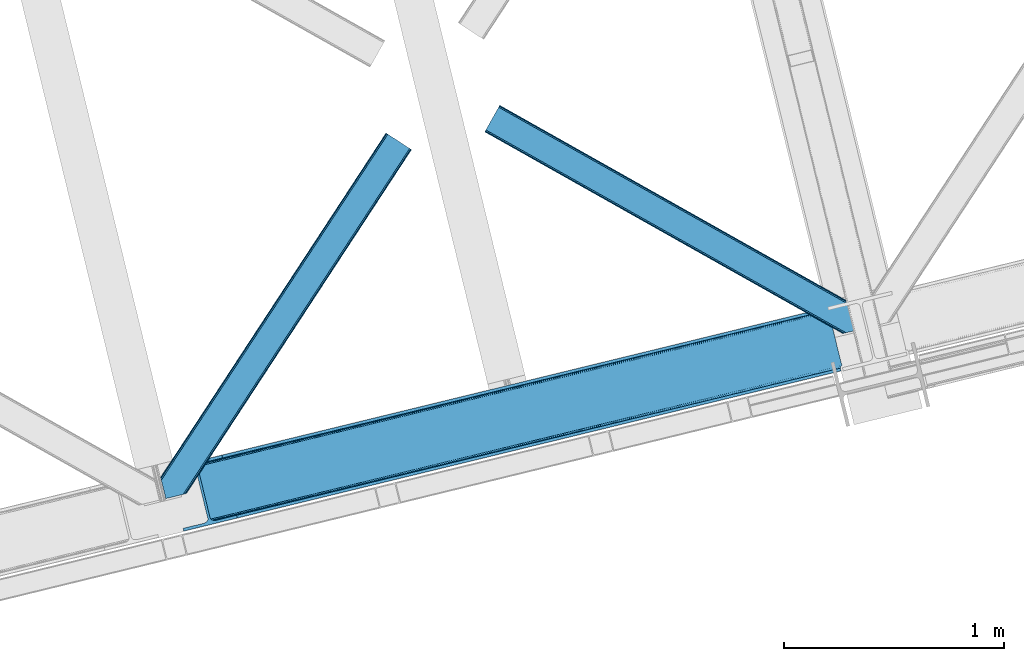
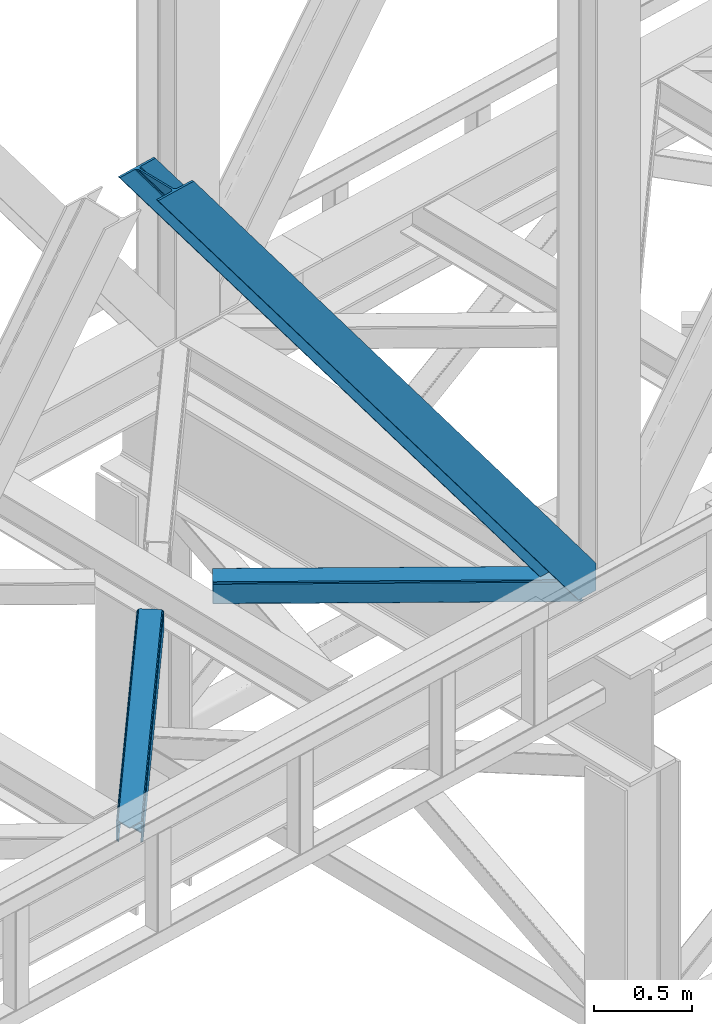
# One storey, part 42 of 92: 3 members.
"""IFC4 building model written with IfcOpenShell, lengths in millimetres."""

import ifcopenshell
import ifcopenshell.guid

model = None  # the IFC model being written
_history = None  # IfcOwnerHistory: only IFC2X3 demands one
_inside = {}  # id of a spatial element -> (the spatial element, [elements in it])
_under = {}  # id of a project, library or spatial element -> (it, [spatial elements below it])
_declared = {}  # id of a project -> (the project, [libraries it declares])
_typed = {}  # id of a type object -> (the type object, [elements of that type])
_made_of = {}  # id of a material, layer set ... -> (it, [elements and type objects made of it])


def new_model(schema):
    """Start an empty IFC model of exactly this schema.

    Asked for "IFC4X3", IfcOpenShell would pick the latest addendum, in which some entities
    have other attributes; the version numbers below select the first issue.
    IFC2X3 requires an IfcOwnerHistory on every rooted entity: one is made here for all.
    """
    global model, _history
    if schema == "IFC4X3":
        model = ifcopenshell.file(schema_version=(4, 3, 0, 0))
    else:
        model = ifcopenshell.file(schema=schema)
    _inside.clear()
    _under.clear()
    _declared.clear()
    _typed.clear()
    _made_of.clear()
    _history = None
    if model.schema == "IFC2X3":
        org = make("IfcOrganization", Name="unknown")
        user = make(
            "IfcPersonAndOrganization",
            ThePerson=make("IfcPerson", FamilyName="unknown"),
            TheOrganization=org,
        )
        app = make(
            "IfcApplication",
            ApplicationDeveloper=org,
            Version="unknown",
            ApplicationFullName="unknown",
            ApplicationIdentifier="unknown",
        )
        _history = make(
            "IfcOwnerHistory",
            OwningUser=user,
            OwningApplication=app,
            ChangeAction="ADDED",
            CreationDate=0,
        )
    return model


def make(cls, **values):
    """One entity of the class cls with the attributes given. An attribute that is None is left unset."""
    return model.create_entity(
        cls, **{name: value for name, value in values.items() if value is not None}
    )


def entity(cls, *values):
    """Any entity or typed value of the class cls, its attributes in the order of the schema. None: left unset."""
    e = model.create_entity(cls)
    for i, value in enumerate(values):
        if value is not None:
            e[i] = value
    return e


def rooted(cls, **values):
    """An entity with a GlobalId (a new one), such as an element, a storey or a relation."""
    return make(cls, GlobalId=ifcopenshell.guid.new(), OwnerHistory=_history, **values)


def si_unit(unit_type, name, prefix=None):
    """IfcSIUnit, for example si_unit("LENGTHUNIT", "METRE", prefix="MILLI")."""
    return make("IfcSIUnit", UnitType=unit_type, Prefix=prefix, Name=name)


def converted_unit(unit_type, name, factor, base, dimensions=None, offset=None):
    """IfcConversionBasedUnit, such as the inch: factor (a typed value) times the base unit."""
    return make(
        "IfcConversionBasedUnit"
        if offset is None
        else "IfcConversionBasedUnitWithOffset",
        ConversionOffset=offset,
        Dimensions=None
        if dimensions is None
        else entity("IfcDimensionalExponents", *dimensions),
        UnitType=unit_type,
        Name=name,
        ConversionFactor=make(
            "IfcMeasureWithUnit", ValueComponent=factor, UnitComponent=base
        ),
    )


def derived_unit(unit_type, elements):
    """IfcDerivedUnit: a product of units, each with its exponent."""
    return make(
        "IfcDerivedUnit",
        Elements=[
            make("IfcDerivedUnitElement", Unit=unit, Exponent=power)
            for unit, power in elements
        ],
        UnitType=unit_type,
    )


def assignment(units):
    """IfcUnitAssignment: the units of a project."""
    return None if units is None else make("IfcUnitAssignment", Units=units)


def point(xyz):
    """IfcCartesianPoint."""
    return None if xyz is None else make("IfcCartesianPoint", Coordinates=xyz)


def direction(xyz):
    """IfcDirection."""
    return None if xyz is None else make("IfcDirection", DirectionRatios=xyz)


def frame(location, z_axis=None, x_axis=None):
    """IfcAxis2Placement3D, a coordinate frame: its origin and axes. An axis left out is left unset."""
    return make(
        "IfcAxis2Placement3D",
        Location=point(location),
        Axis=direction(z_axis),
        RefDirection=direction(x_axis),
    )


def origin():
    """The frame at (0, 0, 0) with its axes left unset."""
    return frame((0.0, 0.0, 0.0))


def place(relative_to, where):
    """IfcLocalPlacement: puts the frame where relative to a parent placement (None: the world)."""
    return make(
        "IfcLocalPlacement", PlacementRelTo=relative_to, RelativePlacement=where
    )


def context(
    kind, dimensions, precision=None, world=None, true_north=None, identifier=None
):
    """IfcGeometricRepresentationContext, for example the 3D "Model" context."""
    return make(
        "IfcGeometricRepresentationContext",
        ContextIdentifier=identifier,
        ContextType=kind,
        CoordinateSpaceDimension=dimensions,
        Precision=precision,
        WorldCoordinateSystem=world,
        TrueNorth=true_north,
    )


def subcontext(parent, identifier, kind, view, scale=None):
    """IfcGeometricRepresentationSubContext, for example "Body" below "Model"."""
    return make(
        "IfcGeometricRepresentationSubContext",
        ContextIdentifier=identifier,
        ContextType=kind,
        ParentContext=parent,
        TargetScale=scale,
        TargetView=view,
    )


def project(units=None, contexts=None):
    """IfcProject with its units and contexts."""
    return rooted(
        "IfcProject",
        Name="project",
        RepresentationContexts=contexts,
        UnitsInContext=assignment(units),
    )


def spatial(cls, under=None, at=None, **own):
    """A site, building, storey or space (cls), placed at a placement, below another one or the project."""
    s = rooted(cls, ObjectPlacement=at, **own)
    if under is not None:
        _under.setdefault(under.id(), (under, []))[1].append(s)
    return s


def point_list(points):
    """IfcCartesianPointList2D or 3D."""
    cls = (
        "IfcCartesianPointList2D" if len(points[0]) == 2 else "IfcCartesianPointList3D"
    )
    return make(cls, CoordList=points)


def triangles(points, corners, closed=None, point_numbers=None):
    """IfcTriangulatedFaceSet: each triangle names its three corners, points numbered from 1."""
    return make(
        "IfcTriangulatedFaceSet",
        Coordinates=point_list(points),
        Closed=closed,
        CoordIndex=corners,
        PnIndex=point_numbers,
    )


def shape(context_of_items, identifier, shape_type, items):
    """IfcShapeRepresentation: the items that make up one representation, for example the "Body"."""
    return make(
        "IfcShapeRepresentation",
        ContextOfItems=context_of_items,
        RepresentationIdentifier=identifier,
        RepresentationType=shape_type,
        Items=items,
    )


def made_of(thing, what):
    """Note that an element or type object is made of a material, layer set ...; save() writes the relation."""
    if what is not None:
        _made_of.setdefault(what.id(), (what, []))[1].append(thing)
    return thing


def type_object(cls, material=None, **own):
    """A type object (cls), such as IfcWallType, which elements share."""
    return made_of(rooted(cls, **own), material)


def element(
    cls,
    number,
    at=None,
    inside=None,
    cuts=None,
    type_object=None,
    material=None,
    context=None,
    identifier="Body",
    shape_type=None,
    held_by="IfcProductDefinitionShape",
    body=None,
    shapes=None,
    **own,
):
    """One element of the class cls, such as IfcWall. Its Tag is "e" and its number.

    at: its placement. inside: the storey or other place that contains it. cuts: it is an
    opening in that element (IfcRelVoidsElement). A single representation is given by context,
    identifier, shape_type and body (its items); several are given by shapes. held_by: the class
    of the entity that holds the representations. save() writes the other relations.
    """
    e = rooted(cls, Tag="e%d" % number, ObjectPlacement=at, **own)
    if body is not None:
        shapes = [shape(context, identifier, shape_type, body)]
    if shapes is not None:
        e.Representation = make(held_by, Representations=shapes)
    if inside is not None:
        _inside.setdefault(inside.id(), (inside, []))[1].append(e)
    if cuts is not None:
        rooted(
            "IfcRelVoidsElement", RelatingBuildingElement=cuts, RelatedOpeningElement=e
        )
    if type_object is not None:
        _typed.setdefault(type_object.id(), (type_object, []))[1].append(e)
    return made_of(e, material)


def aggregate(whole, parts):
    """IfcRelAggregates: a whole, such as a stair, and the parts it consists of."""
    return rooted("IfcRelAggregates", RelatingObject=whole, RelatedObjects=parts)


def save(model, path):
    """Write the relations noted so far, then the file.

    IfcRelAggregates (storeys below a building ...), IfcRelContainedInSpatialStructure (elements
    in a storey), IfcRelDefinesByType, IfcRelAssociatesMaterial and IfcRelDeclares: one each for
    every whole, place, type object, material and project.
    """
    for whole, parts in _under.values():
        aggregate(whole, parts)
    for where, things in _inside.values():
        rooted(
            "IfcRelContainedInSpatialStructure",
            RelatedElements=things,
            RelatingStructure=where,
        )
    for kind, things in _typed.values():
        rooted("IfcRelDefinesByType", RelatedObjects=things, RelatingType=kind)
    for what, things in _made_of.values():
        rooted("IfcRelAssociatesMaterial", RelatedObjects=things, RelatingMaterial=what)
    for by, libraries in _declared.values():
        rooted("IfcRelDeclares", RelatingContext=by, RelatedDefinitions=libraries)
    model.write(path)


model = new_model("IFC4")

# Units and contexts
model_context = context("Model", 3, precision=0.01, world=origin(), true_north=direction((6.12303176911189e-17, 1.0)))
plan_context = context("Plan", 3, precision=0.01, world=origin(), true_north=direction((6.12303176911189e-17, 1.0)))
body_context = subcontext(model_context, "Body", "Model", "MODEL_VIEW")
ifc_project = project(units=[si_unit("LENGTHUNIT", "METRE", prefix="MILLI"), si_unit("AREAUNIT", "SQUARE_METRE"), si_unit("VOLUMEUNIT", "CUBIC_METRE"), converted_unit("PLANEANGLEUNIT", "DEGREE", entity("IfcRatioMeasure", 0.0174532925199433), si_unit("PLANEANGLEUNIT", "RADIAN"), dimensions=[0, 0, 0, 0, 0, 0, 0]), si_unit("MASSUNIT", "GRAM", prefix="KILO"), derived_unit("MASSDENSITYUNIT", [(si_unit("MASSUNIT", "GRAM", prefix="KILO"), 1), (si_unit("LENGTHUNIT", "METRE"), -3)]), derived_unit("MOMENTOFINERTIAUNIT", [(si_unit("LENGTHUNIT", "METRE"), 4)]), si_unit("TIMEUNIT", "SECOND"), si_unit("FREQUENCYUNIT", "HERTZ"), si_unit("THERMODYNAMICTEMPERATUREUNIT", "DEGREE_CELSIUS"), derived_unit("THERMALTRANSMITTANCEUNIT", [(si_unit("MASSUNIT", "GRAM", prefix="KILO"), 1), (si_unit("THERMODYNAMICTEMPERATUREUNIT", "KELVIN"), -1), (si_unit("TIMEUNIT", "SECOND"), -3)]), derived_unit("VOLUMETRICFLOWRATEUNIT", [(si_unit("LENGTHUNIT", "METRE"), 3), (si_unit("TIMEUNIT", "SECOND"), -1)]), derived_unit("MASSFLOWRATEUNIT", [(si_unit("MASSUNIT", "GRAM", prefix="KILO"), 1), (si_unit("TIMEUNIT", "SECOND"), -1)]), derived_unit("ROTATIONALFREQUENCYUNIT", [(si_unit("TIMEUNIT", "SECOND"), -1)]), si_unit("ELECTRICCURRENTUNIT", "AMPERE"), si_unit("ELECTRICVOLTAGEUNIT", "VOLT"), si_unit("POWERUNIT", "WATT"), si_unit("FORCEUNIT", "NEWTON", prefix="KILO"), si_unit("ILLUMINANCEUNIT", "LUX"), si_unit("LUMINOUSFLUXUNIT", "LUMEN"), si_unit("LUMINOUSINTENSITYUNIT", "CANDELA"), derived_unit("USERDEFINED", [(si_unit("MASSUNIT", "GRAM", prefix="KILO"), -1), (si_unit("LENGTHUNIT", "METRE"), -2), (si_unit("TIMEUNIT", "SECOND"), 3), (si_unit("LUMINOUSFLUXUNIT", "LUMEN"), 1)]), derived_unit("LINEARVELOCITYUNIT", [(si_unit("LENGTHUNIT", "METRE"), 1), (si_unit("TIMEUNIT", "SECOND"), -1)]), si_unit("PRESSUREUNIT", "PASCAL"), derived_unit("USERDEFINED", [(si_unit("LENGTHUNIT", "METRE"), -2), (si_unit("MASSUNIT", "GRAM", prefix="KILO"), 1), (si_unit("TIMEUNIT", "SECOND"), -2)]), derived_unit("LINEARFORCEUNIT", [(si_unit("MASSUNIT", "GRAM", prefix="KILO"), 1), (si_unit("LENGTHUNIT", "METRE"), 1), (si_unit("TIMEUNIT", "SECOND"), -2), (si_unit("LENGTHUNIT", "METRE"), -1)]), derived_unit("PLANARFORCEUNIT", [(si_unit("MASSUNIT", "GRAM", prefix="KILO"), 1), (si_unit("LENGTHUNIT", "METRE"), 1), (si_unit("TIMEUNIT", "SECOND"), -2), (si_unit("LENGTHUNIT", "METRE"), -2)])], contexts=[model_context, plan_context])

# Site, building, storey
site_placement = place(None, origin())
site = spatial("IfcSite", under=ifc_project, at=site_placement, CompositionType="ELEMENT")
building_placement = place(site_placement, origin())
building = spatial("IfcBuilding", under=site, at=building_placement, CompositionType="ELEMENT")
storey_placement = place(building_placement, frame((0.0, 0.0, 15900.0)))
storey = spatial("IfcBuildingStorey", under=building, at=storey_placement, Name="05", CompositionType="ELEMENT", Elevation=15900.0)

# Members
member_type_1 = type_object("IfcMemberType", PredefinedType="BRACE")
member_1_placement = place(storey_placement, frame((-45388.13, 6402.95, 3695.0)))
element("IfcMember", 1, at=member_1_placement, inside=storey, type_object=member_type_1, ObjectType="Steel Vertical Brace", PredefinedType="BRACE", context=body_context, shape_type="Tessellation", body=[
    triangles([(3067.37091064453, 755.49225769043, 0.827856445310317), (3068.02668457032, 754.507434082031, 1.13248901367115), (3066.59886474609, 754.04641571045, 0.0), (3064.67805175782, 761.9255859375, 0.0), (3064.21761474609, 752.731379699707, 7.29955444335792), (3064.21761474609, 752.731379699707, 0.0), (3059.99926757813, 741.228012084961, 0.0), (3059.68765869141, 743.591821289063, 30.563250732419), (3059.80393066406, 742.210510253906, 42.2602111816377), (3059.81788330078, 745.528330993652, 0.0), (3059.81788330078, 745.528330993652, 24.1799194335908), (3059.80393066406, 742.210510253906, 171.115136718749), (3059.99926757813, 741.228012084961, 171.175598144531), (3061.30151367188, 749.56936340332, 14.6921264648408), (3061.30151367188, 749.56936340332, 0.0), (3060.7248046875, 747.995622253418, 18.3872497558586), (215.726367187497, 48.9359664916992, 3911.00081176758), (310.455468749999, 72.0264175415041, 3911.00081176758), (192.834741210936, 54.7931671142578, 3911.00081176758), (198.973901367186, 50.2783264160162, 3911.00081176758), (207.010620117188, 48.2214752197269, 3911.00081176758), (189.532617187499, 61.0782485961918, 3911.00081176758), (3062.84095458985, 729.569421386719, 171.175598144531), (313.534350585935, 59.3963745117189, 3911.00081176758), (3062.84095458985, 729.569421386719, 0.0), (2945.0109375, 700.846755981445, 0.0), (69.865502929686, 0.0, 3911.00081176758), (2941.93205566406, 713.477380371094, 0.0), (66.78662109375, 12.6300430297852, 3911.00081176758), (161.511071777342, 35.72049407959, 3911.00081176758), (3036.65650634766, 736.567831420899, 0.0), (3054.3251953125, 759.401321411133, 0.0), (3054.28798828125, 752.301754760742, 0.0), (179.17976074219, 58.5539840698248, 3911.00081176758), (179.142553710939, 51.4549987792971, 3911.00081176758), (3050.91610107422, 745.469613647461, 0.0), (175.770666503908, 44.622857666016, 3911.00081176758), (3044.72578125, 739.944369506836, 0.0), (169.580346679686, 39.0976135253904, 3911.00081176758), (2999.14251708984, 985.772969055176, 0.0), (123.997082519534, 284.925631713867, 3911.00081176758), (2972.95341796875, 997.915251159669, 0.0), (2981.66916503906, 998.629742431641, 0.0), (106.523730468747, 297.782405090332, 3911.00081176758), (97.8033325195283, 297.06791381836, 3911.00081176758), (2989.70588378907, 996.572891235352, 0.0), (114.560449218749, 295.726135253906, 3911.00081176758), (2995.84504394532, 992.05805053711, 0.0), (120.699609374999, 291.211294555665, 3911.00081176758), (3.07888183593604, 273.977462768555, 3911.00081176758), (2878.22431640625, 974.824800109864, 0.0), (2875.14543457031, 987.454843139649, 0.0), (0.0, 286.608087158203, 3911.00081176758), (3009.50002441406, 988.297233581543, 0.0), (134.354589843751, 287.449896240235, 3911.00081176758), (143.954003906249, 306.906848144531, 3911.00081176758), (243.668847656249, 346.004461669922, 3911.00081176758), (152.023278808592, 310.283386230469, 3911.00081176758), (137.763684082034, 301.381604003906, 3911.00081176758), (134.391796875003, 294.549462890625, 3911.00081176758), (246.747729492185, 333.374418640137, 3911.00081176758), (2992.97545166015, 1016.17750854492, 171.175598144531), (2992.97545166015, 1016.17750854492, 0.0), (2995.81713867188, 1004.51891784668, 171.175598144531), (2996.10084228516, 1003.55792999268, 171.115136718749), (2996.10084228516, 1003.55792999268, 42.2602111816377), (2995.81713867188, 1004.51891784668, 0.0), (3004.85844726562, 996.247911071778, 0.0), (2997.63563232422, 1000.6174118042, 0.0), (3000.81218261718, 997.712356567383, 0.0), (3007.57921142578, 996.176403808594, 0.0), (2996.63104248047, 1002.27719421387, 30.563250732419), (2997.80306396484, 1000.74124145508, 25.1542785644524), (2999.21228027344, 998.890191650391, 18.6337463378877), (3000.81218261718, 997.712356567383, 14.6921264648408), (3004.85844726562, 996.247911071778, 7.29955444335792), (3009.05819091797, 996.424063110352, 1.13248901367115), (3008.92796630859, 995.248553466798, 0.827856445310317)], [[1, 2, 3], [3, 4, 1], [5, 6, 3], [7, 8, 9], [7, 10, 11], [11, 8, 7], [9, 12, 13], [13, 7, 9], [14, 10, 15], [10, 14, 16], [11, 10, 16], [6, 5, 15], [14, 15, 5], [3, 2, 5], [17, 18, 12], [12, 9, 17], [1, 19, 5], [19, 20, 16], [16, 14, 19], [14, 5, 19], [20, 21, 8], [8, 11, 20], [9, 8, 21], [21, 17, 9], [11, 16, 20], [5, 2, 1], [1, 4, 19], [22, 19, 4], [13, 12, 18], [23, 13, 24], [18, 24, 13], [23, 25, 7], [7, 13, 23], [24, 26, 23], [24, 27, 26], [26, 25, 23], [28, 26, 29], [27, 29, 26], [29, 30, 28], [31, 28, 30], [32, 33, 34], [35, 34, 33], [33, 36, 35], [37, 35, 36], [36, 38, 37], [39, 37, 38], [38, 31, 39], [30, 39, 31], [40, 32, 41], [34, 41, 32], [42, 43, 44], [44, 45, 42], [43, 46, 47], [47, 44, 43], [46, 48, 49], [49, 47, 46], [48, 40, 41], [41, 49, 48], [45, 50, 51], [51, 42, 45], [52, 51, 50], [50, 53, 52], [4, 54, 55], [55, 22, 4], [41, 34, 55], [37, 39, 21], [30, 27, 24], [29, 27, 30], [39, 30, 17], [34, 35, 19], [35, 37, 20], [47, 56, 44], [53, 45, 57], [45, 44, 58], [53, 50, 45], [47, 49, 59], [49, 41, 60], [55, 34, 22], [17, 21, 39], [19, 35, 20], [21, 20, 37], [19, 22, 34], [24, 17, 30], [24, 18, 17], [58, 44, 56], [59, 49, 60], [55, 60, 41], [59, 56, 47], [58, 57, 45], [57, 58, 61], [57, 52, 53], [52, 57, 62], [63, 52, 62], [64, 62, 57], [65, 64, 61], [57, 61, 64], [61, 58, 65], [66, 65, 58], [64, 67, 62], [63, 62, 67], [32, 40, 54], [46, 43, 67], [42, 52, 63], [51, 52, 42], [43, 42, 63], [40, 48, 68], [48, 46, 69], [36, 7, 38], [26, 31, 25], [31, 38, 25], [26, 28, 31], [36, 33, 10], [33, 32, 6], [10, 7, 36], [54, 40, 68], [67, 69, 46], [63, 67, 43], [48, 69, 70], [70, 68, 48], [71, 54, 68], [32, 54, 4], [10, 33, 15], [33, 6, 15], [7, 25, 38], [32, 4, 6], [3, 6, 4], [67, 72, 73], [65, 66, 64], [67, 64, 66], [66, 72, 67], [69, 74, 75], [69, 73, 74], [76, 77, 71], [71, 68, 76], [76, 68, 70], [70, 75, 76], [75, 70, 69], [73, 69, 67], [60, 78, 76], [76, 59, 60], [76, 75, 59], [75, 74, 59], [78, 77, 76], [54, 78, 60], [60, 55, 54], [73, 59, 74], [59, 73, 72], [56, 59, 72], [72, 66, 56], [58, 56, 66], [77, 78, 71], [54, 71, 78]]),
])
member_type_2 = type_object("IfcMemberType", PredefinedType="BRACE")
member_2_placement = place(storey_placement, frame((-45423.94, 6551.04, 3511.0)))
element("IfcMember", 2, at=member_2_placement, inside=storey, type_object=member_type_2, ObjectType="Steel Horizontal Brace", PredefinedType="BRACE", context=body_context, shape_type="Tessellation", body=[
    triangles([(109.770043945318, 259.949830627442, 7.52047119140843), (115.030187988283, 238.365682983399, 7.77510681152489), (114.216284179689, 239.946981811524, 8.3320495605476), (108.811962890628, 259.662057495118, 8.52041015625218), (113.634924316408, 239.859196472168, 8.52041015625218), (112.20710449219, 237.677352905273, 8.52041015625218), (91.0363037109419, 232.516621398926, 8.52041015625218), (109.537500000006, 237.026229858398, 9.50058288574292), (90.2642578125015, 232.328260803223, 9.50058288574292), (5.02294921875, 77.405158996582, 9.50058288574292), (0.62786865234375, 95.4308029174808, 9.50058288574292), (1046.62448730469, 1651.75324859619, 6.99957275390625), (1041.02017822266, 1655.4216293335, 8.3320495605476), (116.699853515631, 231.514938354492, 6.99957275390625), (1036.27163085938, 1658.53190460205, 12.1260040283232), (3.92999267578125, 81.8752349853521, 12.1260040283232), (1033.09973144531, 1660.61026611328, 17.8035644531265), (2.70216064453416, 86.9220199584961, 17.8035644531265), (1031.98352050781, 1661.3398727417, 24.4996673583992), (2.26962890625146, 88.6940048217775, 24.4996673583992), (1122.7547241211, 1601.90454711914, 6.99957275390625), (146.209680175787, 110.459536743164, 6.99957275390625), (1031.98352050781, 1661.3398727417, 115.501089477541), (2.26962890625146, 88.6940048217775, 115.501089477541), (1033.09973144531, 1660.61026611328, 122.196029663086), (2.70216064453416, 86.9220199584961, 122.196029663086), (1036.27163085938, 1658.53190460205, 127.87475280762), (3.92999267578125, 81.8752349853521, 127.87475280762), (1041.02017822266, 1655.4216293335, 131.667544555665), (5.77174072265916, 74.322789001465, 131.667544555665), (1046.62448730469, 1651.75324859619, 133.000021362306), (7.94370117187646, 65.4140304565435, 133.000021362306), (1027.24427490235, 1664.44433441162, 10.8028289794929), (0.520898437505821, 95.8714736938482, 10.8691040039084), (0.0, 98.0056457519531, 17.5000946044929), (1035.16472167969, 1659.2562789917, 1.33247680664135), (112.258264160162, 249.73533782959, 1.33247680664135), (110.546740722661, 256.772117614746, 5.59500732422021), (109.077062988283, 259.839372253418, 8.31925964355469), (1030.41617431641, 1662.36655426025, 5.12526855468968), (1040.76903076172, 1655.58789825439, 0.0), (114.430224609379, 240.826579284668, 0.0), (1026.12806396485, 1665.1745223999, 17.5000946044929), (1128.61018066407, 1598.06989746094, 0.0), (148.479309082031, 101.147314453126, 0.0), (150.651269531256, 92.2385559082031, 1.33247680664135), (148.507214355472, 101.029298400879, 8.50064392089917), (152.493017578126, 84.686109924317, 5.12526855468968), (153.348779296881, 81.1822540283201, 8.50064392089917), (1026.12806396485, 1665.1745223999, 122.500662231447), (0.0, 98.0056457519531, 122.500662231447), (1040.76903076172, 1655.58789825439, 139.999594116212), (1035.16472167969, 1659.2562789917, 138.667117309571), (3.50211181640771, 83.6350112915043, 138.667117309571), (5.674072265625, 74.7256713867191, 139.999594116212), (1030.41617431641, 1662.36655426025, 134.874325561526), (1.66036376953707, 91.1874572753904, 134.874325561526), (1027.24427490235, 1664.44433441162, 129.197927856447), (0.432531738282705, 96.2336608886717, 129.197927856447), (23.8915649414121, 0.0, 139.999594116212), (23.8915649414121, 0.0, 133.000021362306), (1128.61018066407, 1598.06989746094, 139.999594116212), (93.3338378906265, 16.9280364990236, 139.999594116212), (1122.7547241211, 1601.90454711914, 133.000021362306), (83.3809570312515, 14.501440429688, 133.000021362306), (1143.25579833984, 1588.48385467529, 122.500662231447), (1142.13958740234, 1589.21346130371, 129.197927856447), (118.225341796875, 22.9951080322271, 122.500662231447), (116.332434082033, 22.5335083007813, 129.197927856447), (1138.96303710938, 1591.29124145508, 134.874325561526), (110.937414550783, 21.2178909301756, 134.874325561526), (1134.2144897461, 1594.40151672363, 138.667117309571), (102.858837890628, 19.2499877929686, 138.667117309571), (1143.25579833984, 1588.48385467529, 17.5000946044929), (118.225341796875, 22.9951080322271, 17.5000946044929), (1142.13958740234, 1589.21346130371, 10.8028289794929), (1133.10758056641, 1595.12647247314, 12.1260040283232), (1136.28413085938, 1593.04811096191, 17.8035644531265), (1137.39569091797, 1592.3185043335, 24.4996673583992), (1138.96303710938, 1591.29124145508, 5.12526855468968), (1134.2144897461, 1594.40151672363, 1.33247680664135), (1128.35903320313, 1598.23616638184, 8.3320495605476), (1133.10758056641, 1595.12647247314, 127.87475280762), (1137.39569091797, 1592.3185043335, 115.501089477541), (1136.28413085938, 1593.04811096191, 122.196029663086), (1128.35903320313, 1598.23616638184, 131.667544555665), (92.9059570312529, 16.8228103637693, 131.667544555665), (100.979882812506, 18.79129486084, 127.87475280762), (106.374902343756, 20.106330871582, 122.196029663086), (108.267810058598, 20.5685119628906, 115.501089477541), (108.267810058598, 20.5685119628906, 24.4996673583992), (100.979882812506, 18.79129486084, 12.1260040283232), (115.472021484376, 22.32421875, 9.50058288574292), (106.374902343756, 20.106330871582, 17.8035644531265), (96.1987792968794, 17.6262496948248, 9.50058288574292), (115.946411132813, 22.4393280029299, 10.8702667236357), (153.060424804688, 80.2392883300781, 9.00061340332104), (152.776721191411, 79.2969039916998, 9.50058288574292), (148.711853027344, 99.8677413940432, 8.8831787109375), (148.604882812506, 99.023606872559, 9.08781738281323), (148.493261718751, 98.1672637939455, 9.29478149414354), (148.381640625004, 97.3225479125977, 9.50058288574292)], [[1, 2, 3], [4, 5, 6], [6, 7, 4], [7, 6, 8], [8, 9, 7], [9, 8, 10], [10, 11, 9], [12, 13, 3], [3, 2, 12], [2, 14, 12], [15, 16, 8], [8, 13, 15], [8, 5, 13], [16, 10, 8], [8, 6, 5], [15, 17, 18], [18, 16, 15], [17, 19, 20], [20, 18, 17], [21, 12, 14], [14, 22, 21], [19, 23, 20], [24, 20, 23], [23, 25, 24], [26, 24, 25], [25, 27, 26], [28, 26, 27], [27, 29, 28], [30, 28, 29], [29, 31, 30], [32, 30, 31], [33, 34, 35], [36, 37, 38], [33, 4, 9], [33, 1, 39], [9, 34, 33], [9, 11, 34], [4, 7, 9], [40, 38, 1], [1, 33, 40], [38, 40, 36], [36, 41, 37], [42, 37, 41], [35, 43, 33], [41, 44, 42], [45, 42, 44], [14, 42, 22], [37, 2, 38], [2, 37, 42], [38, 2, 1], [42, 14, 2], [22, 42, 45], [46, 47, 45], [47, 46, 48], [45, 47, 22], [48, 49, 47], [50, 43, 35], [35, 51, 50], [52, 53, 54], [54, 55, 52], [53, 56, 57], [57, 54, 53], [56, 58, 59], [59, 57, 56], [58, 50, 51], [51, 59, 58], [28, 57, 26], [30, 32, 55], [32, 60, 55], [32, 61, 60], [54, 30, 55], [28, 54, 57], [16, 11, 10], [28, 30, 54], [51, 35, 20], [24, 26, 51], [24, 51, 20], [57, 59, 26], [26, 59, 51], [35, 18, 20], [18, 11, 16], [11, 18, 34], [35, 34, 18], [62, 55, 63], [62, 52, 55], [55, 60, 63], [64, 32, 31], [32, 64, 65], [61, 32, 65], [66, 67, 68], [69, 68, 67], [67, 70, 69], [71, 69, 70], [70, 72, 71], [73, 71, 72], [72, 62, 73], [63, 73, 62], [74, 66, 75], [68, 75, 66], [76, 77, 78], [79, 66, 74], [76, 78, 74], [76, 80, 77], [78, 79, 74], [77, 80, 81], [21, 44, 41], [44, 82, 81], [82, 44, 21], [82, 77, 81], [67, 83, 70], [84, 66, 79], [66, 85, 67], [85, 66, 84], [67, 85, 83], [62, 64, 52], [72, 70, 83], [83, 86, 72], [86, 64, 62], [62, 72, 86], [15, 36, 40], [41, 12, 21], [41, 13, 12], [13, 41, 36], [15, 13, 36], [19, 43, 50], [33, 17, 15], [40, 33, 15], [17, 33, 43], [19, 17, 43], [53, 27, 56], [52, 64, 31], [31, 29, 52], [29, 27, 53], [53, 52, 29], [58, 56, 27], [50, 23, 19], [25, 50, 58], [50, 25, 23], [25, 58, 27], [64, 86, 87], [87, 65, 64], [86, 83, 88], [88, 87, 86], [83, 85, 89], [89, 88, 83], [85, 84, 90], [90, 89, 85], [84, 79, 90], [91, 90, 79], [89, 68, 69], [87, 73, 63], [60, 65, 63], [65, 60, 61], [65, 87, 63], [88, 73, 87], [88, 89, 71], [71, 73, 88], [69, 71, 89], [91, 75, 68], [92, 93, 94], [89, 90, 68], [92, 95, 93], [91, 94, 75], [90, 91, 68], [96, 75, 94], [94, 93, 96], [76, 74, 75], [49, 80, 97], [98, 97, 80], [49, 48, 80], [76, 96, 98], [98, 80, 76], [96, 93, 98], [44, 81, 45], [46, 45, 81], [81, 80, 46], [48, 46, 80], [75, 96, 76], [82, 21, 22], [77, 82, 47], [47, 99, 77], [77, 100, 101], [100, 77, 99], [101, 102, 77], [77, 102, 92], [95, 92, 102], [22, 47, 82], [79, 78, 91], [94, 91, 78], [78, 77, 94], [92, 94, 77], [102, 101, 98], [101, 100, 97], [100, 99, 49], [99, 47, 49], [102, 98, 93], [93, 95, 102]]),
])
member_type_3 = type_object("IfcMemberType", PredefinedType="BRACE")
member_3_placement = place(storey_placement, frame((-43947.87, 7302.47, 3511.0)))
element("IfcMember", 3, at=member_3_placement, inside=storey, type_object=member_type_3, ObjectType="Steel Horizontal Brace", PredefinedType="BRACE", context=body_context, shape_type="Tessellation", body=[
    triangles([(1645.8158203125, 3.74512023925763, 138.667117309571), (1655.3408203125, 6.06707153320258, 139.999594116212), (8.59017333984229, 933.436047363281, 139.999594116212), (5.302001953125, 927.600938415528, 138.667117309571), (1637.74189453125, 1.7772171020506, 134.874325561526), (2.51612548828416, 922.653565979004, 134.874325561526), (1632.346875, 0.461599731444949, 129.197927856447), (0.65577392578416, 919.34853515625, 129.197927856447), (1630.44931640625, 0.0, 122.500662231447), (0.0, 918.187559509277, 122.500662231447), (1630.44931640625, 0.0, 17.5000946044929), (0.0, 918.187559509277, 17.5000946044929), (1706.57490234375, 97.721360778809, 139.999594116212), (1724.78774414062, 22.9956893920898, 139.999594116212), (60.1126098632813, 1024.92639312744, 139.999594116212), (1701.3287109375, 119.229350280762, 129.197927856447), (1700.89617919922, 121.001335144043, 122.500662231447), (68.0423583984375, 1039.01390533447, 129.197927856447), (68.6981323242217, 1040.17488098145, 122.500662231447), (1702.56119384766, 114.18314666748, 134.874325561526), (66.1820068359375, 1035.70829315186, 134.874325561526), (1704.40294189453, 106.630700683594, 138.667117309571), (63.3961303710967, 1030.76150207519, 138.667117309571), (1700.89617919922, 121.001335144043, 17.5000946044929), (68.6981323242217, 1040.17488098145, 17.5000946044929), (0.65577392578416, 919.34853515625, 10.8028289794929), (1633.02590332031, 0.628450012206486, 10.9377044677749), (2.51612548828416, 922.653565979004, 5.12526855468968), (5.302001953125, 927.600938415528, 1.33247680664135), (1569.79720458984, 46.5547164916989, 1.33247680664135), (1573.68999023437, 34.8100845336912, 8.52041015625218), (1571.51337890625, 39.517936706543, 5.59500732422021), (1572.2900756836, 36.3402236938473, 7.52047119140843), (1572.98770751953, 35.5751541137697, 8.02044067383031), (1573.35047607422, 35.1809921264648, 8.278564453125), (1572.62958984375, 35.9693161010746, 7.76231689453198), (1633.97933349609, 0.859831237792605, 8.52041015625218), (1567.62524414063, 55.4634750366213, 0.0), (8.59017333984229, 933.436047363281, 0.0), (1533.58081054688, 195.142739868164, 0.0), (60.1126098632813, 1024.92639312744, 0.0), (1566.73227539063, 59.1411575317379, 7.52047119140843), (1567.24852294922, 57.3430114746097, 7.90300598144677), (1567.78337402343, 56.436090087891, 8.1076446533225), (1568.32752685547, 55.5198669433594, 8.31460876464917), (1568.41124267578, 55.3762710571291, 8.3471649169951), (1568.86237792969, 54.6129455566406, 8.52041015625218), (1655.15013427734, 6.02056274414008, 8.52041015625218), (5.953125, 928.75319366455, 12.1260040283232), (1647.69942626953, 4.20381317138617, 12.1260040283232), (8.73900146484084, 933.699984741212, 8.3320495605476), (12.0225219726563, 939.535093688964, 6.99957275390625), (1565.35561523437, 64.7751159667969, 6.99957275390625), (1642.29975585938, 2.88877716064417, 17.8035644531265), (4.08812255859084, 925.447581481934, 17.8035644531265), (1640.40684814453, 2.42659606933557, 24.4996673583992), (3.43699951171584, 924.287187194825, 24.4996673583992), (1640.40684814453, 2.42659606933557, 115.501089477541), (3.43699951171584, 924.287187194825, 115.501089477541), (1647.69942626953, 4.20381317138617, 127.87475280762), (1655.77335205078, 6.17229766845685, 131.667544555665), (1642.29975585938, 2.88877716064417, 122.196029663086), (1665.29835205078, 8.4942489624018, 133.000021362306), (1724.78774414062, 22.9956893920898, 133.000021362306), (4.08812255859084, 925.447581481934, 122.196029663086), (5.953125, 928.75319366455, 127.87475280762), (8.73900146484084, 933.699984741212, 131.667544555665), (12.0225219726563, 939.535093688964, 133.000021362306), (1708.84453125, 88.4097198486324, 133.000021362306), (56.6756103515654, 1018.82676544189, 133.000021362306), (1535.85043945313, 185.830517578125, 6.99957275390625), (56.6756103515654, 1018.82676544189, 6.99957275390625), (68.0423583984375, 1039.01390533447, 10.8028289794929), (62.7496582031235, 1029.60924682617, 12.1260040283232), (64.6100097656235, 1032.91485900879, 17.8035644531265), (65.2611328124985, 1034.0752532959, 24.4996673583992), (66.1820068359375, 1035.70829315186, 5.12526855468968), (63.3961303710967, 1030.76150207519, 1.33247680664135), (59.9637817382827, 1024.66245574951, 8.3320495605476), (62.7496582031235, 1029.60924682617, 127.87475280762), (65.2611328124985, 1034.0752532959, 115.501089477541), (64.6100097656235, 1032.91485900879, 122.196029663086), (59.9637817382827, 1024.66245574951, 131.667544555665), (1703.16580810547, 111.689694213867, 24.4996673583992), (1703.16580810547, 111.689694213867, 115.501089477541), (1706.67257080078, 97.3184783935549, 131.667544555665), (1704.83082275391, 104.870924377441, 127.87475280762), (1703.59833984375, 109.917709350586, 122.196029663086), (1704.83082275391, 104.870924377441, 12.1260040283232), (1706.52839355469, 97.9004196166989, 8.52041015625218), (1701.70078125, 117.703280639648, 8.52041015625218), (1703.59833984375, 109.917709350586, 17.8035644531265), (1701.48684082031, 118.591017150879, 10.9365417480476), (1534.47377929687, 191.464476013183, 7.52047119140843), (1529.69267578125, 211.087696838379, 5.59500732422021), (1528.9159790039, 214.265991210938, 7.52047119140843), (1531.40885009766, 204.051498413086, 1.33247680664135), (1529.11596679688, 214.689221191406, 8.22740478515698), (1529.01829833984, 214.477606201172, 7.87393798828271), (1529.90196533203, 214.452026367188, 8.52041015625218), (1534.34820556641, 192.705679321289, 7.85649719238427), (1534.72957763672, 194.649165344238, 8.52041015625218)], [[1, 2, 3], [3, 4, 1], [5, 1, 4], [4, 6, 5], [7, 5, 6], [6, 8, 7], [9, 7, 8], [8, 10, 9], [11, 9, 10], [10, 12, 11], [2, 13, 3], [2, 14, 13], [15, 3, 13], [16, 17, 18], [19, 18, 17], [20, 16, 21], [18, 21, 16], [22, 20, 23], [21, 23, 20], [13, 22, 15], [23, 15, 22], [17, 24, 19], [25, 19, 24], [26, 27, 11], [28, 29, 30], [27, 26, 31], [26, 28, 32], [32, 33, 26], [34, 35, 26], [35, 31, 26], [26, 36, 34], [26, 33, 36], [31, 37, 27], [30, 32, 28], [38, 30, 29], [29, 39, 38], [11, 12, 26], [40, 38, 39], [39, 41, 40], [33, 42, 43], [36, 43, 44], [34, 44, 45], [35, 46, 47], [35, 45, 46], [47, 31, 35], [45, 35, 34], [44, 34, 36], [43, 36, 33], [48, 37, 47], [31, 47, 37], [49, 50, 47], [47, 51, 49], [47, 46, 51], [50, 48, 47], [52, 43, 42], [51, 46, 45], [45, 52, 51], [45, 44, 52], [43, 52, 44], [42, 53, 52], [54, 50, 49], [49, 55, 54], [56, 54, 55], [55, 57, 56], [58, 56, 57], [57, 59, 58], [60, 61, 1], [5, 60, 1], [5, 7, 62], [60, 5, 62], [62, 7, 9], [61, 2, 1], [14, 63, 64], [14, 2, 63], [61, 63, 2], [62, 9, 58], [56, 11, 54], [9, 56, 58], [11, 27, 54], [9, 11, 56], [37, 54, 27], [50, 54, 37], [48, 50, 37], [62, 58, 65], [59, 65, 58], [60, 62, 66], [65, 66, 62], [61, 60, 67], [66, 67, 60], [63, 61, 68], [67, 68, 61], [69, 63, 68], [63, 69, 64], [68, 70, 69], [53, 71, 52], [72, 52, 71], [73, 74, 75], [76, 19, 25], [73, 75, 25], [73, 77, 74], [75, 76, 25], [74, 77, 78], [72, 41, 39], [41, 79, 78], [79, 41, 72], [79, 74, 78], [18, 80, 21], [81, 19, 76], [19, 82, 18], [82, 19, 81], [18, 82, 80], [15, 70, 3], [23, 21, 80], [80, 83, 23], [83, 70, 15], [15, 23, 83], [49, 29, 28], [39, 52, 72], [39, 51, 52], [51, 39, 29], [49, 51, 29], [57, 12, 10], [26, 55, 49], [28, 26, 49], [55, 26, 12], [57, 55, 12], [4, 66, 6], [3, 70, 68], [68, 67, 3], [67, 66, 4], [4, 3, 67], [8, 6, 66], [10, 59, 57], [65, 10, 8], [10, 65, 59], [65, 8, 66], [84, 85, 76], [81, 76, 85], [86, 69, 70], [70, 83, 86], [87, 86, 83], [83, 80, 87], [88, 87, 80], [80, 82, 88], [85, 88, 82], [82, 81, 85], [87, 20, 22], [89, 90, 91], [20, 87, 88], [86, 87, 22], [86, 13, 69], [14, 69, 13], [69, 14, 64], [86, 22, 13], [24, 17, 84], [91, 92, 89], [92, 24, 84], [93, 92, 91], [93, 24, 92], [17, 85, 84], [88, 16, 20], [17, 16, 88], [85, 17, 88], [40, 71, 53], [94, 95, 96], [40, 94, 71], [94, 97, 95], [94, 40, 97], [38, 40, 53], [42, 38, 53], [32, 42, 33], [42, 30, 38], [42, 32, 30], [73, 25, 24], [98, 99, 77], [96, 77, 99], [96, 95, 77], [73, 93, 100], [100, 77, 73], [100, 98, 77], [93, 91, 100], [78, 77, 95], [97, 40, 41], [41, 78, 97], [95, 97, 78], [24, 93, 73], [72, 71, 94], [94, 79, 72], [101, 102, 79], [79, 94, 101], [74, 79, 102], [90, 89, 102], [74, 102, 89], [92, 84, 75], [76, 75, 84], [89, 92, 74], [75, 74, 92], [101, 94, 99], [102, 101, 99], [91, 90, 102], [102, 100, 91]]),
])

save(model, "model.ifc")
